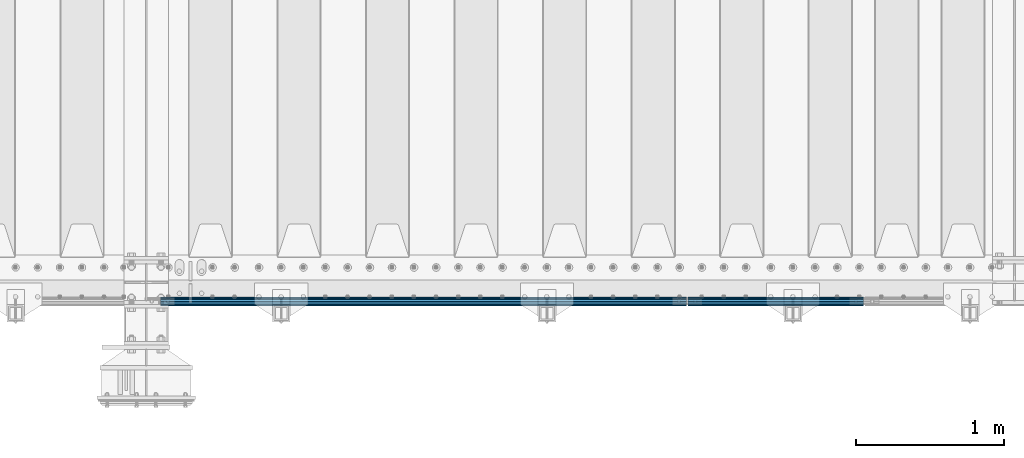
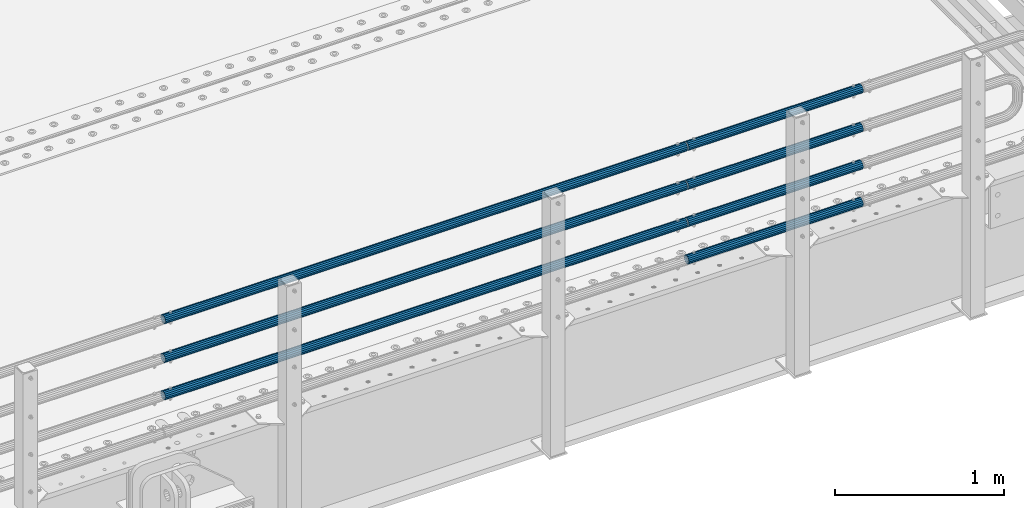
# One storey, part 128 of 242: 7 beams.
"""IFC2X3 building model written with IfcOpenShell, lengths in millimetres."""

from ifc_helpers import new_model, si_unit, frame, origin_with_axes, place, context, subcontext, project, spatial, faceted_brep, material, type_object, element, save


model = new_model("IFC2X3")

# Units and contexts
model_context = context("Model", 3, precision=1e-05, world=origin_with_axes())
body_context = subcontext(model_context, "Body", "Model", "MODEL_VIEW")
ifc_project = project(units=[si_unit("LENGTHUNIT", "METRE", prefix="MILLI"), si_unit("AREAUNIT", "SQUARE_METRE"), si_unit("VOLUMEUNIT", "CUBIC_METRE"), si_unit("MASSUNIT", "GRAM", prefix="KILO"), si_unit("TIMEUNIT", "SECOND"), si_unit("PLANEANGLEUNIT", "RADIAN"), si_unit("SOLIDANGLEUNIT", "STERADIAN"), si_unit("THERMODYNAMICTEMPERATUREUNIT", "DEGREE_CELSIUS"), si_unit("LUMINOUSINTENSITYUNIT", "LUMEN")], contexts=[model_context])

# Site, building, storey
site_placement = place(None, origin_with_axes())
site = spatial("IfcSite", under=ifc_project, at=site_placement, CompositionType="ELEMENT")
building_placement = place(site_placement, origin_with_axes())
building = spatial("IfcBuilding", under=site, at=building_placement, Name="Standard", CompositionType="ELEMENT")
storey_placement = place(building_placement, origin_with_axes())
storey = spatial("IfcBuildingStorey", under=building, at=storey_placement, Name="Undefined", CompositionType="ELEMENT", Elevation=0.0)

# Beams
ifc_material = material()
beam_type = type_object("IfcBeamType", PredefinedType="NOTDEFINED")
beam_1_placement = place(storey_placement, frame((-24755.0000000001, -24129.8499999998, 420.149999999725), z_axis=(0.0, 0.0, -1.0), x_axis=(-1.0, 0.0, 0.0)))
element("IfcBeam", 1, at=beam_1_placement, inside=storey, type_object=beam_type, material=ifc_material, context=body_context, shape_type="Brep", body=[
    faceted_brep([(0.0, -26.5499999999993, 0.0), (0.0, -24.5290015881765, 10.1602451292931), (3563.0, -24.5290015881765, 10.1602451292931), (3563.0, -26.5499999999993, 0.0), (0.0, -18.7736850405017, 18.7736850405028), (3563.0, -18.7736850405017, 18.7736850405028), (0.0, -10.1602451292929, 24.5290015881747), (3563.0, -10.1602451292929, 24.5290015881747), (0.0, 0.0, 26.55), (3563.0, 0.0, 26.55), (0.0, 10.1602451292929, 24.5290015881747), (3563.0, 10.1602451292929, 24.5290015881747), (0.0, 18.7736850405017, 18.7736850405028), (3563.0, 18.7736850405017, 18.7736850405028), (0.0, 24.5290015881765, 10.1602451292931), (3563.0, 24.5290015881765, 10.1602451292931), (0.0, 26.5499999999993, 0.0), (3563.0, 26.5499999999993, 0.0), (0.0, 24.5290015881765, -10.1602451292931), (3563.0, 24.5290015881765, -10.1602451292931), (0.0, 18.7736850405017, -18.7736850405028), (3563.0, 18.7736850405017, -18.7736850405028), (0.0, 10.1602451292929, -24.5290015881747), (3563.0, 10.1602451292929, -24.5290015881747), (0.0, 0.0, -26.55), (3563.0, 0.0, -26.55), (0.0, -10.1602451292929, -24.5290015881747), (3563.0, -10.1602451292929, -24.5290015881747), (0.0, -18.7736850405017, -18.7736850405028), (3563.0, -18.7736850405017, -18.7736850405028), (0.0, -24.5290015881765, -10.1602451292931), (3563.0, -24.5290015881765, -10.1602451292931), (0.0, -30.1500000000015, 0.0), (0.0, -27.8549679052157, -11.5379054858058), (3563.0, -27.8549679052157, -11.5379054858075), (3563.0, -30.1500000000015, 0.0), (0.0, -21.3192694527752, -21.3192694527752), (3563.0, -21.3192694527752, -21.3192694527744), (0.0, -11.5379054858058, -27.8549679052157), (3563.0, -11.5379054858058, -27.8549679052153), (0.0, 0.0, -30.1500000000015), (3563.0, 0.0, -30.15), (0.0, 11.5379054858058, -27.8549679052157), (3563.0, 11.5379054858058, -27.8549679052153), (0.0, 21.3192694527752, -21.3192694527752), (3563.0, 21.3192694527752, -21.3192694527744), (0.0, 27.8549679052157, -11.5379054858058), (3563.0, 27.8549679052157, -11.5379054858074), (0.0, 30.1500000000015, 0.0), (3563.0, 30.1500000000015, 0.0), (0.0, 27.8549679052157, 11.5379054858058), (3563.0, 27.8549679052157, 11.5379054858075), (0.0, 21.3192694527752, 21.3192694527752), (3563.0, 21.3192694527752, 21.3192694527744), (0.0, 11.5379054858058, 27.8549679052157), (3563.0, 11.5379054858058, 27.8549679052153), (0.0, 0.0, 30.1500000000015), (3563.0, 0.0, 30.15), (0.0, -11.5379054858058, 27.8549679052157), (3563.0, -11.5379054858058, 27.8549679052153), (0.0, -21.3192694527752, 21.3192694527752), (3563.0, -21.3192694527752, 21.3192694527744), (0.0, -27.8549679052157, 11.5379054858058), (3563.0, -27.8549679052157, 11.5379054858075)], [[[0, 1, 2, 3]], [[1, 4, 5, 2]], [[4, 6, 7, 5]], [[6, 8, 9, 7]], [[8, 10, 11, 9]], [[10, 12, 13, 11]], [[12, 14, 15, 13]], [[14, 16, 17, 15]], [[16, 18, 19, 17]], [[18, 20, 21, 19]], [[20, 22, 23, 21]], [[22, 24, 25, 23]], [[24, 26, 27, 25]], [[26, 28, 29, 27]], [[28, 30, 31, 29]], [[30, 0, 3, 31]], [[32, 33, 34, 35]], [[33, 36, 37, 34]], [[36, 38, 39, 37]], [[38, 40, 41, 39]], [[40, 42, 43, 41]], [[42, 44, 45, 43]], [[44, 46, 47, 45]], [[46, 48, 49, 47]], [[48, 50, 51, 49]], [[50, 52, 53, 51]], [[52, 54, 55, 53]], [[54, 56, 57, 55]], [[56, 58, 59, 57]], [[58, 60, 61, 59]], [[60, 62, 63, 61]], [[62, 32, 35, 63]], [[37, 39, 41, 43, 45, 47, 49, 51, 53, 55, 57, 59, 61, 63, 35, 34], [5, 7, 9, 11, 13, 15, 17, 19, 21, 23, 25, 27, 29, 31, 3, 2]], [[62, 60, 58, 56, 54, 52, 50, 48, 46, 44, 42, 40, 38, 36, 33, 32], [30, 28, 26, 24, 22, 20, 18, 16, 14, 12, 10, 8, 6, 4, 1, 0]]]),
])
beam_2_placement = place(storey_placement, frame((-24755.0000000001, -24129.8499999998, 969.849999999726), z_axis=(0.0, 0.0, -1.0), x_axis=(-1.0, 0.0, 0.0)))
element("IfcBeam", 2, at=beam_2_placement, inside=storey, type_object=beam_type, material=ifc_material, context=body_context, shape_type="Brep", body=[
    faceted_brep([(0.0, -26.5499999999993, 0.0), (0.0, -24.5290015881765, 10.1602451292931), (3563.0, -24.5290015881765, 10.1602451292931), (3563.0, -26.5499999999993, 0.0), (0.0, -18.7736850405017, 18.7736850405028), (3563.0, -18.7736850405017, 18.7736850405028), (0.0, -10.1602451292929, 24.5290015881747), (3563.0, -10.1602451292929, 24.5290015881747), (0.0, 0.0, 26.55), (3563.0, 0.0, 26.55), (0.0, 10.1602451292929, 24.5290015881747), (3563.0, 10.1602451292929, 24.5290015881747), (0.0, 18.7736850405017, 18.7736850405028), (3563.0, 18.7736850405017, 18.7736850405028), (0.0, 24.5290015881765, 10.1602451292931), (3563.0, 24.5290015881765, 10.1602451292931), (0.0, 26.5499999999993, 0.0), (3563.0, 26.5499999999993, 0.0), (0.0, 24.5290015881765, -10.1602451292931), (3563.0, 24.5290015881765, -10.1602451292931), (0.0, 18.7736850405017, -18.7736850405028), (3563.0, 18.7736850405017, -18.7736850405028), (0.0, 10.1602451292929, -24.5290015881747), (3563.0, 10.1602451292929, -24.5290015881747), (0.0, 0.0, -26.55), (3563.0, 0.0, -26.55), (0.0, -10.1602451292929, -24.5290015881747), (3563.0, -10.1602451292929, -24.5290015881747), (0.0, -18.7736850405017, -18.7736850405028), (3563.0, -18.7736850405017, -18.7736850405028), (0.0, -24.5290015881765, -10.1602451292931), (3563.0, -24.5290015881765, -10.1602451292931), (0.0, -30.1500000000015, 0.0), (0.0, -27.8549679052157, -11.5379054858058), (3563.0, -27.8549679052157, -11.5379054858075), (3563.0, -30.1500000000015, 0.0), (0.0, -21.3192694527752, -21.3192694527752), (3563.0, -21.3192694527752, -21.3192694527744), (0.0, -11.5379054858058, -27.8549679052157), (3563.0, -11.5379054858058, -27.8549679052153), (0.0, 0.0, -30.1500000000015), (3563.0, 0.0, -30.15), (0.0, 11.5379054858058, -27.8549679052157), (3563.0, 11.5379054858058, -27.8549679052153), (0.0, 21.3192694527752, -21.3192694527752), (3563.0, 21.3192694527752, -21.3192694527744), (0.0, 27.8549679052157, -11.5379054858058), (3563.0, 27.8549679052157, -11.5379054858074), (0.0, 30.1500000000015, 0.0), (3563.0, 30.1500000000015, 0.0), (0.0, 27.8549679052157, 11.5379054858058), (3563.0, 27.8549679052157, 11.5379054858075), (0.0, 21.3192694527752, 21.3192694527752), (3563.0, 21.3192694527752, 21.3192694527744), (0.0, 11.5379054858058, 27.8549679052157), (3563.0, 11.5379054858058, 27.8549679052153), (0.0, 0.0, 30.1500000000015), (3563.0, 0.0, 30.15), (0.0, -11.5379054858058, 27.8549679052157), (3563.0, -11.5379054858058, 27.8549679052153), (0.0, -21.3192694527752, 21.3192694527752), (3563.0, -21.3192694527752, 21.3192694527744), (0.0, -27.8549679052157, 11.5379054858058), (3563.0, -27.8549679052157, 11.5379054858075)], [[[0, 1, 2, 3]], [[1, 4, 5, 2]], [[4, 6, 7, 5]], [[6, 8, 9, 7]], [[8, 10, 11, 9]], [[10, 12, 13, 11]], [[12, 14, 15, 13]], [[14, 16, 17, 15]], [[16, 18, 19, 17]], [[18, 20, 21, 19]], [[20, 22, 23, 21]], [[22, 24, 25, 23]], [[24, 26, 27, 25]], [[26, 28, 29, 27]], [[28, 30, 31, 29]], [[30, 0, 3, 31]], [[32, 33, 34, 35]], [[33, 36, 37, 34]], [[36, 38, 39, 37]], [[38, 40, 41, 39]], [[40, 42, 43, 41]], [[42, 44, 45, 43]], [[44, 46, 47, 45]], [[46, 48, 49, 47]], [[48, 50, 51, 49]], [[50, 52, 53, 51]], [[52, 54, 55, 53]], [[54, 56, 57, 55]], [[56, 58, 59, 57]], [[58, 60, 61, 59]], [[60, 62, 63, 61]], [[62, 32, 35, 63]], [[37, 39, 41, 43, 45, 47, 49, 51, 53, 55, 57, 59, 61, 63, 35, 34], [5, 7, 9, 11, 13, 15, 17, 19, 21, 23, 25, 27, 29, 31, 3, 2]], [[62, 60, 58, 56, 54, 52, 50, 48, 46, 44, 42, 40, 38, 36, 33, 32], [30, 28, 26, 24, 22, 20, 18, 16, 14, 12, 10, 8, 6, 4, 1, 0]]]),
])
beam_3_placement = place(storey_placement, frame((-24744.9999999999, -24129.8500000004, 419.849999999726), z_axis=(0.0, -1.0, 0.0), x_axis=(1.0, 0.0, 0.0)))
element("IfcBeam", 3, at=beam_3_placement, inside=storey, type_object=beam_type, material=ifc_material, context=body_context, shape_type="Brep", body=[
    faceted_brep([(0.0, -26.5499999999993, 0.0), (0.0, -24.5290015881765, 10.1602451292931), (1190.0, -24.5290015881747, 10.1602451292929), (1190.0, -26.55, 0.0), (0.0, -18.7736850405017, 18.7736850405028), (1190.0, -18.7736850405028, 18.7736850405017), (0.0, -10.1602451292929, 24.5290015881747), (1190.0, -10.1602451292931, 24.5290015881765), (0.0, 0.0, 26.55), (1190.0, 0.0, 26.5499999999993), (0.0, 10.1602451292929, 24.5290015881747), (1190.0, 10.1602451292932, 24.5290015881765), (0.0, 18.7736850405017, 18.7736850405028), (1190.0, 18.7736850405029, 18.7736850405017), (0.0, 24.5290015881765, 10.1602451292931), (1190.0, 24.5290015881747, 10.1602451292929), (0.0, 26.5499999999993, 0.0), (1190.0, 26.55, 0.0), (0.0, 24.5290015881765, -10.1602451292931), (1190.0, 24.5290015881747, -10.1602451292929), (0.0, 18.7736850405017, -18.7736850405028), (1190.0, 18.7736850405028, -18.7736850405017), (0.0, 10.1602451292929, -24.5290015881747), (1190.0, 10.1602451292931, -24.5290015881765), (0.0, 0.0, -26.55), (1190.0, 0.0, -26.5499999999993), (0.0, -10.1602451292929, -24.5290015881747), (1190.0, -10.1602451292931, -24.5290015881765), (0.0, -18.7736850405017, -18.7736850405028), (1190.0, -18.7736850405028, -18.7736850405017), (0.0, -24.5290015881765, -10.1602451292931), (1190.0, -24.5290015881747, -10.1602451292929), (0.0, -30.1500000000015, 0.0), (0.0, -27.8549679052157, -11.5379054858058), (1190.0, -27.8549679052153, -11.5379054858058), (1190.0, -30.15, 0.0), (0.0, -21.3192694527752, -21.3192694527752), (1190.0, -21.3192694527744, -21.3192694527752), (0.0, -11.5379054858058, -27.8549679052157), (1190.0, -11.5379054858075, -27.8549679052157), (0.0, 0.0, -30.1500000000015), (1190.0, 0.0, -30.1500000000015), (0.0, 11.5379054858058, -27.8549679052157), (1190.0, 11.5379054858075, -27.8549679052157), (0.0, 21.3192694527752, -21.3192694527752), (1190.0, 21.3192694527744, -21.3192694527752), (0.0, 27.8549679052157, -11.5379054858058), (1190.0, 27.8549679052153, -11.5379054858058), (0.0, 30.1500000000015, 0.0), (1190.0, 30.15, 0.0), (0.0, 27.8549679052157, 11.5379054858058), (1190.0, 27.8549679052153, 11.5379054858058), (0.0, 21.3192694527752, 21.3192694527752), (1190.0, 21.3192694527744, 21.3192694527752), (0.0, 11.5379054858058, 27.8549679052157), (1190.0, 11.5379054858075, 27.8549679052157), (0.0, 0.0, 30.1500000000015), (1190.0, 0.0, 30.1500000000015), (0.0, -11.5379054858058, 27.8549679052157), (1190.0, -11.5379054858075, 27.8549679052157), (0.0, -21.3192694527752, 21.3192694527752), (1190.0, -21.3192694527744, 21.3192694527752), (0.0, -27.8549679052157, 11.5379054858058), (1190.0, -27.8549679052153, 11.5379054858058)], [[[0, 1, 2, 3]], [[1, 4, 5, 2]], [[4, 6, 7, 5]], [[6, 8, 9, 7]], [[8, 10, 11, 9]], [[10, 12, 13, 11]], [[12, 14, 15, 13]], [[14, 16, 17, 15]], [[16, 18, 19, 17]], [[18, 20, 21, 19]], [[20, 22, 23, 21]], [[22, 24, 25, 23]], [[24, 26, 27, 25]], [[26, 28, 29, 27]], [[28, 30, 31, 29]], [[30, 0, 3, 31]], [[32, 33, 34, 35]], [[33, 36, 37, 34]], [[36, 38, 39, 37]], [[38, 40, 41, 39]], [[40, 42, 43, 41]], [[42, 44, 45, 43]], [[44, 46, 47, 45]], [[46, 48, 49, 47]], [[48, 50, 51, 49]], [[50, 52, 53, 51]], [[52, 54, 55, 53]], [[54, 56, 57, 55]], [[56, 58, 59, 57]], [[58, 60, 61, 59]], [[60, 62, 63, 61]], [[62, 32, 35, 63]], [[37, 39, 41, 43, 45, 47, 49, 51, 53, 55, 57, 59, 61, 63, 35, 34], [5, 7, 9, 11, 13, 15, 17, 19, 21, 23, 25, 27, 29, 31, 3, 2]], [[62, 60, 58, 56, 54, 52, 50, 48, 46, 44, 42, 40, 38, 36, 33, 32], [30, 28, 26, 24, 22, 20, 18, 16, 14, 12, 10, 8, 6, 4, 1, 0]]]),
])
beam_4_placement = place(storey_placement, frame((-24744.9999999999, -24129.8500000004, 149.549999999726), z_axis=(0.0, -1.0, 0.0), x_axis=(1.0, 0.0, 0.0)))
element("IfcBeam", 4, at=beam_4_placement, inside=storey, type_object=beam_type, material=ifc_material, context=body_context, shape_type="Brep", body=[
    faceted_brep([(0.0, -26.5499999999993, 0.0), (0.0, -24.5290015881765, 10.1602451292931), (1190.0, -24.5290015881747, 10.1602451292929), (1190.0, -26.55, 0.0), (0.0, -18.7736850405017, 18.7736850405028), (1190.0, -18.7736850405028, 18.7736850405017), (0.0, -10.1602451292929, 24.5290015881747), (1190.0, -10.1602451292931, 24.5290015881765), (0.0, 0.0, 26.55), (1190.0, 0.0, 26.5499999999993), (0.0, 10.1602451292929, 24.5290015881747), (1190.0, 10.1602451292932, 24.5290015881765), (0.0, 18.7736850405017, 18.7736850405028), (1190.0, 18.7736850405029, 18.7736850405017), (0.0, 24.5290015881765, 10.1602451292931), (1190.0, 24.5290015881747, 10.1602451292929), (0.0, 26.5499999999993, 0.0), (1190.0, 26.55, 0.0), (0.0, 24.5290015881765, -10.1602451292931), (1190.0, 24.5290015881747, -10.1602451292929), (0.0, 18.7736850405017, -18.7736850405028), (1190.0, 18.7736850405028, -18.7736850405017), (0.0, 10.1602451292929, -24.5290015881747), (1190.0, 10.1602451292931, -24.5290015881765), (0.0, 0.0, -26.55), (1190.0, 0.0, -26.5499999999993), (0.0, -10.1602451292929, -24.5290015881747), (1190.0, -10.1602451292931, -24.5290015881765), (0.0, -18.7736850405017, -18.7736850405028), (1190.0, -18.7736850405028, -18.7736850405017), (0.0, -24.5290015881765, -10.1602451292931), (1190.0, -24.5290015881747, -10.1602451292929), (0.0, -30.1500000000015, 0.0), (0.0, -27.8549679052157, -11.5379054858058), (1190.0, -27.8549679052153, -11.5379054858058), (1190.0, -30.15, 0.0), (0.0, -21.3192694527752, -21.3192694527752), (1190.0, -21.3192694527744, -21.3192694527752), (0.0, -11.5379054858058, -27.8549679052157), (1190.0, -11.5379054858075, -27.8549679052157), (0.0, 0.0, -30.1500000000015), (1190.0, 0.0, -30.1500000000015), (0.0, 11.5379054858058, -27.8549679052157), (1190.0, 11.5379054858075, -27.8549679052157), (0.0, 21.3192694527752, -21.3192694527752), (1190.0, 21.3192694527744, -21.3192694527752), (0.0, 27.8549679052157, -11.5379054858058), (1190.0, 27.8549679052153, -11.5379054858058), (0.0, 30.1500000000015, 0.0), (1190.0, 30.15, 0.0), (0.0, 27.8549679052157, 11.5379054858058), (1190.0, 27.8549679052153, 11.5379054858058), (0.0, 21.3192694527752, 21.3192694527752), (1190.0, 21.3192694527744, 21.3192694527752), (0.0, 11.5379054858058, 27.8549679052157), (1190.0, 11.5379054858075, 27.8549679052157), (0.0, 0.0, 30.1500000000015), (1190.0, 0.0, 30.1500000000015), (0.0, -11.5379054858058, 27.8549679052157), (1190.0, -11.5379054858075, 27.8549679052157), (0.0, -21.3192694527752, 21.3192694527752), (1190.0, -21.3192694527744, 21.3192694527752), (0.0, -27.8549679052157, 11.5379054858058), (1190.0, -27.8549679052153, 11.5379054858058)], [[[0, 1, 2, 3]], [[1, 4, 5, 2]], [[4, 6, 7, 5]], [[6, 8, 9, 7]], [[8, 10, 11, 9]], [[10, 12, 13, 11]], [[12, 14, 15, 13]], [[14, 16, 17, 15]], [[16, 18, 19, 17]], [[18, 20, 21, 19]], [[20, 22, 23, 21]], [[22, 24, 25, 23]], [[24, 26, 27, 25]], [[26, 28, 29, 27]], [[28, 30, 31, 29]], [[30, 0, 3, 31]], [[32, 33, 34, 35]], [[33, 36, 37, 34]], [[36, 38, 39, 37]], [[38, 40, 41, 39]], [[40, 42, 43, 41]], [[42, 44, 45, 43]], [[44, 46, 47, 45]], [[46, 48, 49, 47]], [[48, 50, 51, 49]], [[50, 52, 53, 51]], [[52, 54, 55, 53]], [[54, 56, 57, 55]], [[56, 58, 59, 57]], [[58, 60, 61, 59]], [[60, 62, 63, 61]], [[62, 32, 35, 63]], [[37, 39, 41, 43, 45, 47, 49, 51, 53, 55, 57, 59, 61, 63, 35, 34], [5, 7, 9, 11, 13, 15, 17, 19, 21, 23, 25, 27, 29, 31, 3, 2]], [[62, 60, 58, 56, 54, 52, 50, 48, 46, 44, 42, 40, 38, 36, 33, 32], [30, 28, 26, 24, 22, 20, 18, 16, 14, 12, 10, 8, 6, 4, 1, 0]]]),
])
beam_5_placement = place(storey_placement, frame((-24744.9999999999, -24129.8500000004, 969.549999999726), z_axis=(0.0, -1.0, 0.0), x_axis=(1.0, 0.0, 0.0)))
element("IfcBeam", 5, at=beam_5_placement, inside=storey, type_object=beam_type, material=ifc_material, context=body_context, shape_type="Brep", body=[
    faceted_brep([(0.0, -26.5499999999993, 0.0), (0.0, -24.5290015881765, 10.1602451292931), (1190.0, -24.5290015881747, 10.1602451292929), (1190.0, -26.55, 0.0), (0.0, -18.7736850405017, 18.7736850405028), (1190.0, -18.7736850405028, 18.7736850405017), (0.0, -10.1602451292929, 24.5290015881747), (1190.0, -10.1602451292931, 24.5290015881765), (0.0, 0.0, 26.55), (1190.0, 0.0, 26.5499999999993), (0.0, 10.1602451292929, 24.5290015881747), (1190.0, 10.1602451292932, 24.5290015881765), (0.0, 18.7736850405017, 18.7736850405028), (1190.0, 18.7736850405029, 18.7736850405017), (0.0, 24.5290015881765, 10.1602451292931), (1190.0, 24.5290015881747, 10.1602451292929), (0.0, 26.5499999999993, 0.0), (1190.0, 26.55, 0.0), (0.0, 24.5290015881765, -10.1602451292931), (1190.0, 24.5290015881747, -10.1602451292929), (0.0, 18.7736850405017, -18.7736850405028), (1190.0, 18.7736850405028, -18.7736850405017), (0.0, 10.1602451292929, -24.5290015881747), (1190.0, 10.1602451292931, -24.5290015881765), (0.0, 0.0, -26.55), (1190.0, 0.0, -26.5499999999993), (0.0, -10.1602451292929, -24.5290015881747), (1190.0, -10.1602451292931, -24.5290015881765), (0.0, -18.7736850405017, -18.7736850405028), (1190.0, -18.7736850405028, -18.7736850405017), (0.0, -24.5290015881765, -10.1602451292931), (1190.0, -24.5290015881747, -10.1602451292929), (0.0, -30.1500000000015, 0.0), (0.0, -27.8549679052157, -11.5379054858058), (1190.0, -27.8549679052153, -11.5379054858058), (1190.0, -30.15, 0.0), (0.0, -21.3192694527752, -21.3192694527752), (1190.0, -21.3192694527744, -21.3192694527752), (0.0, -11.5379054858058, -27.8549679052157), (1190.0, -11.5379054858075, -27.8549679052157), (0.0, 0.0, -30.1500000000015), (1190.0, 0.0, -30.1500000000015), (0.0, 11.5379054858058, -27.8549679052157), (1190.0, 11.5379054858075, -27.8549679052157), (0.0, 21.3192694527752, -21.3192694527752), (1190.0, 21.3192694527744, -21.3192694527752), (0.0, 27.8549679052157, -11.5379054858058), (1190.0, 27.8549679052153, -11.5379054858058), (0.0, 30.1500000000015, 0.0), (1190.0, 30.15, 0.0), (0.0, 27.8549679052157, 11.5379054858058), (1190.0, 27.8549679052153, 11.5379054858058), (0.0, 21.3192694527752, 21.3192694527752), (1190.0, 21.3192694527744, 21.3192694527752), (0.0, 11.5379054858058, 27.8549679052157), (1190.0, 11.5379054858075, 27.8549679052157), (0.0, 0.0, 30.1500000000015), (1190.0, 0.0, 30.1500000000015), (0.0, -11.5379054858058, 27.8549679052157), (1190.0, -11.5379054858075, 27.8549679052157), (0.0, -21.3192694527752, 21.3192694527752), (1190.0, -21.3192694527744, 21.3192694527752), (0.0, -27.8549679052157, 11.5379054858058), (1190.0, -27.8549679052153, 11.5379054858058)], [[[0, 1, 2, 3]], [[1, 4, 5, 2]], [[4, 6, 7, 5]], [[6, 8, 9, 7]], [[8, 10, 11, 9]], [[10, 12, 13, 11]], [[12, 14, 15, 13]], [[14, 16, 17, 15]], [[16, 18, 19, 17]], [[18, 20, 21, 19]], [[20, 22, 23, 21]], [[22, 24, 25, 23]], [[24, 26, 27, 25]], [[26, 28, 29, 27]], [[28, 30, 31, 29]], [[30, 0, 3, 31]], [[32, 33, 34, 35]], [[33, 36, 37, 34]], [[36, 38, 39, 37]], [[38, 40, 41, 39]], [[40, 42, 43, 41]], [[42, 44, 45, 43]], [[44, 46, 47, 45]], [[46, 48, 49, 47]], [[48, 50, 51, 49]], [[50, 52, 53, 51]], [[52, 54, 55, 53]], [[54, 56, 57, 55]], [[56, 58, 59, 57]], [[58, 60, 61, 59]], [[60, 62, 63, 61]], [[62, 32, 35, 63]], [[37, 39, 41, 43, 45, 47, 49, 51, 53, 55, 57, 59, 61, 63, 35, 34], [5, 7, 9, 11, 13, 15, 17, 19, 21, 23, 25, 27, 29, 31, 3, 2]], [[62, 60, 58, 56, 54, 52, 50, 48, 46, 44, 42, 40, 38, 36, 33, 32], [30, 28, 26, 24, 22, 20, 18, 16, 14, 12, 10, 8, 6, 4, 1, 0]]]),
])
beam_6_placement = place(storey_placement, frame((-24744.9999999999, -24129.8500000004, 689.549999999726), z_axis=(0.0, -1.0, 0.0), x_axis=(1.0, 0.0, 0.0)))
element("IfcBeam", 6, at=beam_6_placement, inside=storey, type_object=beam_type, material=ifc_material, context=body_context, shape_type="Brep", body=[
    faceted_brep([(0.0, -26.5499999999993, 0.0), (0.0, -24.5290015881765, 10.1602451292931), (1190.0, -24.5290015881747, 10.1602451292929), (1190.0, -26.55, 0.0), (0.0, -18.7736850405017, 18.7736850405028), (1190.0, -18.7736850405028, 18.7736850405017), (0.0, -10.1602451292929, 24.5290015881747), (1190.0, -10.1602451292931, 24.5290015881765), (0.0, 0.0, 26.55), (1190.0, 0.0, 26.5499999999993), (0.0, 10.1602451292929, 24.5290015881747), (1190.0, 10.1602451292932, 24.5290015881765), (0.0, 18.7736850405017, 18.7736850405028), (1190.0, 18.7736850405029, 18.7736850405017), (0.0, 24.5290015881765, 10.1602451292931), (1190.0, 24.5290015881747, 10.1602451292929), (0.0, 26.5499999999993, 0.0), (1190.0, 26.55, 0.0), (0.0, 24.5290015881765, -10.1602451292931), (1190.0, 24.5290015881747, -10.1602451292929), (0.0, 18.7736850405017, -18.7736850405028), (1190.0, 18.7736850405028, -18.7736850405017), (0.0, 10.1602451292929, -24.5290015881747), (1190.0, 10.1602451292931, -24.5290015881765), (0.0, 0.0, -26.55), (1190.0, 0.0, -26.5499999999993), (0.0, -10.1602451292929, -24.5290015881747), (1190.0, -10.1602451292931, -24.5290015881765), (0.0, -18.7736850405017, -18.7736850405028), (1190.0, -18.7736850405028, -18.7736850405017), (0.0, -24.5290015881765, -10.1602451292931), (1190.0, -24.5290015881747, -10.1602451292929), (0.0, -30.1500000000015, 0.0), (0.0, -27.8549679052157, -11.5379054858058), (1190.0, -27.8549679052153, -11.5379054858058), (1190.0, -30.15, 0.0), (0.0, -21.3192694527752, -21.3192694527752), (1190.0, -21.3192694527744, -21.3192694527752), (0.0, -11.5379054858058, -27.8549679052157), (1190.0, -11.5379054858075, -27.8549679052157), (0.0, 0.0, -30.1500000000015), (1190.0, 0.0, -30.1500000000015), (0.0, 11.5379054858058, -27.8549679052157), (1190.0, 11.5379054858075, -27.8549679052157), (0.0, 21.3192694527752, -21.3192694527752), (1190.0, 21.3192694527744, -21.3192694527752), (0.0, 27.8549679052157, -11.5379054858058), (1190.0, 27.8549679052153, -11.5379054858058), (0.0, 30.1500000000015, 0.0), (1190.0, 30.15, 0.0), (0.0, 27.8549679052157, 11.5379054858058), (1190.0, 27.8549679052153, 11.5379054858058), (0.0, 21.3192694527752, 21.3192694527752), (1190.0, 21.3192694527744, 21.3192694527752), (0.0, 11.5379054858058, 27.8549679052157), (1190.0, 11.5379054858075, 27.8549679052157), (0.0, 0.0, 30.1500000000015), (1190.0, 0.0, 30.1500000000015), (0.0, -11.5379054858058, 27.8549679052157), (1190.0, -11.5379054858075, 27.8549679052157), (0.0, -21.3192694527752, 21.3192694527752), (1190.0, -21.3192694527744, 21.3192694527752), (0.0, -27.8549679052157, 11.5379054858058), (1190.0, -27.8549679052153, 11.5379054858058)], [[[0, 1, 2, 3]], [[1, 4, 5, 2]], [[4, 6, 7, 5]], [[6, 8, 9, 7]], [[8, 10, 11, 9]], [[10, 12, 13, 11]], [[12, 14, 15, 13]], [[14, 16, 17, 15]], [[16, 18, 19, 17]], [[18, 20, 21, 19]], [[20, 22, 23, 21]], [[22, 24, 25, 23]], [[24, 26, 27, 25]], [[26, 28, 29, 27]], [[28, 30, 31, 29]], [[30, 0, 3, 31]], [[32, 33, 34, 35]], [[33, 36, 37, 34]], [[36, 38, 39, 37]], [[38, 40, 41, 39]], [[40, 42, 43, 41]], [[42, 44, 45, 43]], [[44, 46, 47, 45]], [[46, 48, 49, 47]], [[48, 50, 51, 49]], [[50, 52, 53, 51]], [[52, 54, 55, 53]], [[54, 56, 57, 55]], [[56, 58, 59, 57]], [[58, 60, 61, 59]], [[60, 62, 63, 61]], [[62, 32, 35, 63]], [[37, 39, 41, 43, 45, 47, 49, 51, 53, 55, 57, 59, 61, 63, 35, 34], [5, 7, 9, 11, 13, 15, 17, 19, 21, 23, 25, 27, 29, 31, 3, 2]], [[62, 60, 58, 56, 54, 52, 50, 48, 46, 44, 42, 40, 38, 36, 33, 32], [30, 28, 26, 24, 22, 20, 18, 16, 14, 12, 10, 8, 6, 4, 1, 0]]]),
])
beam_7_placement = place(storey_placement, frame((-24755.0000000001, -24129.8499999998, 689.849999999726), z_axis=(0.0, 0.0, -1.0), x_axis=(-1.0, 0.0, 0.0)))
element("IfcBeam", 7, at=beam_7_placement, inside=storey, type_object=beam_type, material=ifc_material, context=body_context, shape_type="Brep", body=[
    faceted_brep([(0.0, -26.5499999999993, 0.0), (0.0, -24.5290015881765, 10.1602451292931), (3563.0, -24.5290015881765, 10.1602451292931), (3563.0, -26.5499999999993, 0.0), (0.0, -18.7736850405017, 18.7736850405028), (3563.0, -18.7736850405017, 18.7736850405028), (0.0, -10.1602451292929, 24.5290015881747), (3563.0, -10.1602451292929, 24.5290015881747), (0.0, 0.0, 26.55), (3563.0, 0.0, 26.55), (0.0, 10.1602451292929, 24.5290015881747), (3563.0, 10.1602451292929, 24.5290015881747), (0.0, 18.7736850405017, 18.7736850405028), (3563.0, 18.7736850405017, 18.7736850405028), (0.0, 24.5290015881765, 10.1602451292931), (3563.0, 24.5290015881765, 10.1602451292931), (0.0, 26.5499999999993, 0.0), (3563.0, 26.5499999999993, 0.0), (0.0, 24.5290015881765, -10.1602451292931), (3563.0, 24.5290015881765, -10.1602451292931), (0.0, 18.7736850405017, -18.7736850405028), (3563.0, 18.7736850405017, -18.7736850405028), (0.0, 10.1602451292929, -24.5290015881747), (3563.0, 10.1602451292929, -24.5290015881747), (0.0, 0.0, -26.55), (3563.0, 0.0, -26.55), (0.0, -10.1602451292929, -24.5290015881747), (3563.0, -10.1602451292929, -24.5290015881747), (0.0, -18.7736850405017, -18.7736850405028), (3563.0, -18.7736850405017, -18.7736850405028), (0.0, -24.5290015881765, -10.1602451292931), (3563.0, -24.5290015881765, -10.1602451292931), (0.0, -30.1500000000015, 0.0), (0.0, -27.8549679052157, -11.5379054858058), (3563.0, -27.8549679052157, -11.5379054858075), (3563.0, -30.1500000000015, 0.0), (0.0, -21.3192694527752, -21.3192694527752), (3563.0, -21.3192694527752, -21.3192694527744), (0.0, -11.5379054858058, -27.8549679052157), (3563.0, -11.5379054858058, -27.8549679052153), (0.0, 0.0, -30.1500000000015), (3563.0, 0.0, -30.15), (0.0, 11.5379054858058, -27.8549679052157), (3563.0, 11.5379054858058, -27.8549679052153), (0.0, 21.3192694527752, -21.3192694527752), (3563.0, 21.3192694527752, -21.3192694527744), (0.0, 27.8549679052157, -11.5379054858058), (3563.0, 27.8549679052157, -11.5379054858074), (0.0, 30.1500000000015, 0.0), (3563.0, 30.1500000000015, 0.0), (0.0, 27.8549679052157, 11.5379054858058), (3563.0, 27.8549679052157, 11.5379054858075), (0.0, 21.3192694527752, 21.3192694527752), (3563.0, 21.3192694527752, 21.3192694527744), (0.0, 11.5379054858058, 27.8549679052157), (3563.0, 11.5379054858058, 27.8549679052153), (0.0, 0.0, 30.1500000000015), (3563.0, 0.0, 30.15), (0.0, -11.5379054858058, 27.8549679052157), (3563.0, -11.5379054858058, 27.8549679052153), (0.0, -21.3192694527752, 21.3192694527752), (3563.0, -21.3192694527752, 21.3192694527744), (0.0, -27.8549679052157, 11.5379054858058), (3563.0, -27.8549679052157, 11.5379054858075)], [[[0, 1, 2, 3]], [[1, 4, 5, 2]], [[4, 6, 7, 5]], [[6, 8, 9, 7]], [[8, 10, 11, 9]], [[10, 12, 13, 11]], [[12, 14, 15, 13]], [[14, 16, 17, 15]], [[16, 18, 19, 17]], [[18, 20, 21, 19]], [[20, 22, 23, 21]], [[22, 24, 25, 23]], [[24, 26, 27, 25]], [[26, 28, 29, 27]], [[28, 30, 31, 29]], [[30, 0, 3, 31]], [[32, 33, 34, 35]], [[33, 36, 37, 34]], [[36, 38, 39, 37]], [[38, 40, 41, 39]], [[40, 42, 43, 41]], [[42, 44, 45, 43]], [[44, 46, 47, 45]], [[46, 48, 49, 47]], [[48, 50, 51, 49]], [[50, 52, 53, 51]], [[52, 54, 55, 53]], [[54, 56, 57, 55]], [[56, 58, 59, 57]], [[58, 60, 61, 59]], [[60, 62, 63, 61]], [[62, 32, 35, 63]], [[37, 39, 41, 43, 45, 47, 49, 51, 53, 55, 57, 59, 61, 63, 35, 34], [5, 7, 9, 11, 13, 15, 17, 19, 21, 23, 25, 27, 29, 31, 3, 2]], [[62, 60, 58, 56, 54, 52, 50, 48, 46, 44, 42, 40, 38, 36, 33, 32], [30, 28, 26, 24, 22, 20, 18, 16, 14, 12, 10, 8, 6, 4, 1, 0]]]),
])

save(model, "model.ifc")
